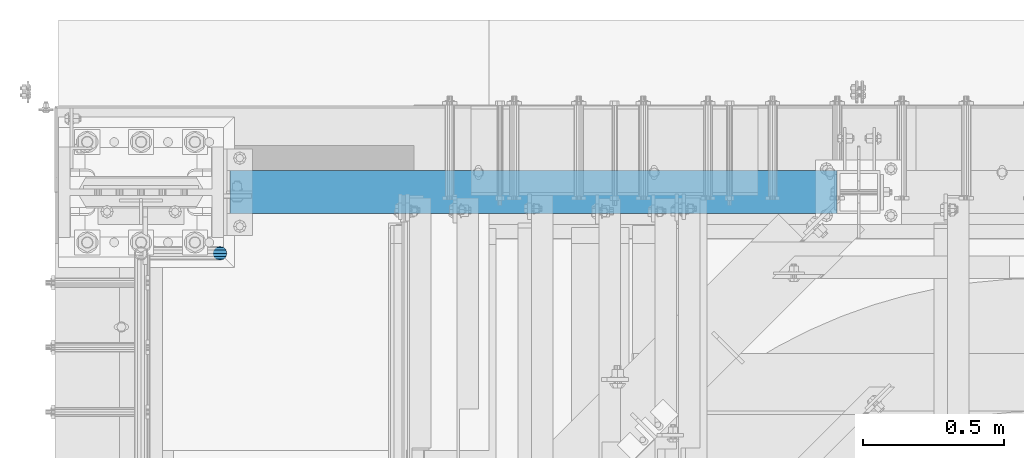
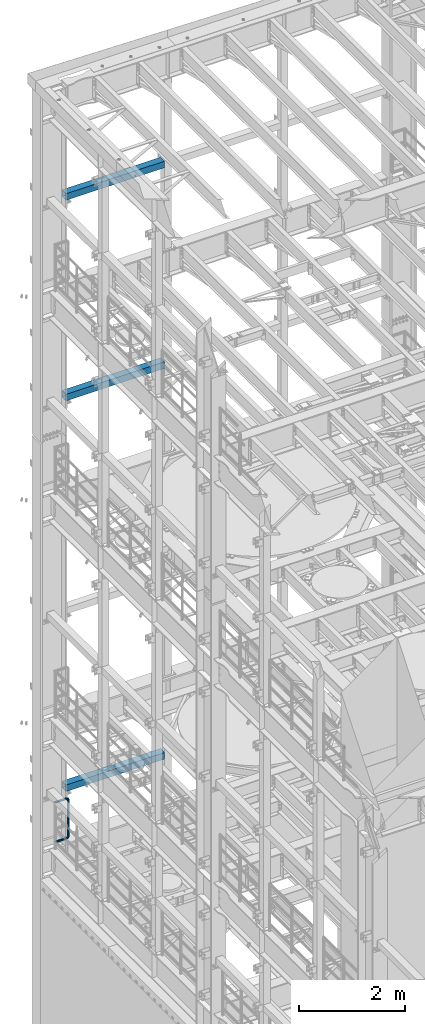
# One storey, part 1057 of 1876: 4 beams, 4 elements without a shape of their own.
"""IFC2X3 building model written with IfcOpenShell, lengths in millimetres."""

from ifc_helpers import new_model, si_unit, frame, origin_with_axes, place, context, subcontext, project, spatial, faceted_brep, material, type_object, element, aggregate, save


model = new_model("IFC2X3")

# Units and contexts
model_context = context("Model", 3, precision=1e-05, world=origin_with_axes())
body_context = subcontext(model_context, "Body", "Model", "MODEL_VIEW")
ifc_project = project(units=[si_unit("LENGTHUNIT", "METRE", prefix="MILLI"), si_unit("AREAUNIT", "SQUARE_METRE"), si_unit("VOLUMEUNIT", "CUBIC_METRE"), si_unit("MASSUNIT", "GRAM", prefix="KILO"), si_unit("TIMEUNIT", "SECOND"), si_unit("PLANEANGLEUNIT", "RADIAN"), si_unit("SOLIDANGLEUNIT", "STERADIAN"), si_unit("THERMODYNAMICTEMPERATUREUNIT", "DEGREE_CELSIUS"), si_unit("LUMINOUSINTENSITYUNIT", "LUMEN")], contexts=[model_context])

# Site, building, storey
site_placement = place(None, origin_with_axes())
site = spatial("IfcSite", under=ifc_project, at=site_placement, CompositionType="ELEMENT")
building_placement = place(site_placement, origin_with_axes())
building = spatial("IfcBuilding", under=site, at=building_placement, Name="Undefined", CompositionType="ELEMENT")
storey_placement = place(building_placement, origin_with_axes())
storey = spatial("IfcBuildingStorey", under=building, at=storey_placement, Name="Undefined", CompositionType="ELEMENT", Elevation=0.0)

# Assembly, beam
assembly_1_placement = place(storey_placement, origin_with_axes())
assembly_1 = element("IfcElementAssembly", 1, at=assembly_1_placement, inside=storey, Name="RAIL", AssemblyPlace="NOTDEFINED", PredefinedType="RIGID_FRAME")
ifc_material_1 = material()
beam_type_1 = type_object("IfcBeamType", Name="PIPE1-1/2SCH40", PredefinedType="NOTDEFINED")
beam_1_placement = place(assembly_1_placement, frame((-3.18323145620525e-12, 13499.7063, 6207.125), z_axis=(0.0, 0.0, 1.0), x_axis=(1.0, 0.0, 0.0)))
beam_1 = element("IfcBeam", 2, at=beam_1_placement, type_object=beam_type_1, material=ifc_material_1, Name="RAIL", ObjectType="PIPE1-1/2SCH40", context=body_context, shape_type="Brep", body=[
    faceted_brep([(1.20714750983051e-12, 24.1299999999974, -914.399963378906), (12.0650000000014, 20.8971929933159, -926.464963378905), (12.0650000000014, 20.8971929933177, -902.334963378908), (12.0650000000014, -20.8971929933195, -902.334963378908), (12.0650000000014, -20.8971929933195, -926.464963378905), (1.52133659548828e-12, -24.130000000001, -914.399963378906), (20.8971929933199, -12.0650000000023, -893.502770385589), (20.8971929933199, -12.0650000000005, -898.533841947723), (15.2545715621378, -17.7076214311819, -904.176463378906), (12.5151929933181, -20.4470000000019, -914.399963378906), (15.2545715621376, -17.7076214311819, -924.623463378906), (20.8971929933199, -12.0650000000005, -930.26608481009), (20.8971929933199, -12.0650000000023, -935.297156372224), (24.1300000000014, -1.81898940354586e-12, -934.846963378906), (24.1300000000014, -1.81898940354586e-12, -938.529963378907), (21.3906214311813, -10.2235000000019, -932.107584810088), (21.3906214311823, 10.2234999999982, -932.107584810088), (20.8971929933199, 12.0650000000005, -930.266084810086), (20.8971929933199, 12.0649999999987, -935.297156372224), (15.2545715621413, 17.7076214311783, -924.623463378906), (12.5151929933216, 20.4469999999983, -914.399963378906), (15.2545715621411, 17.7076214311783, -904.176463378906), (20.8971929933199, 12.0650000000005, -898.533841947727), (20.8971929933199, 12.0649999999987, -893.502770385589), (21.3906214311822, 10.2234999999982, -896.692341947724), (24.1300000000014, 0.0, -893.952963378906), (24.1300000000014, 0.0, -890.269963378905), (21.3906214311814, -10.2235000000019, -896.692341947724), (241.299995422363, -20.8971929933177, 12.0649999999987), (241.299995422363, -24.1299999999992, 0.0), (253.073542436527, -24.1299999999992, -1.86474665447167), (256.801832473661, -20.8971929933177, 9.60975021462946), (241.299995422363, -12.0650000000005, 20.8971929933177), (259.531130206197, -12.0650000000005, 18.0096649141014), (241.299995422363, 0.0, 24.130000000001), (260.530122510796, 0.0, 21.084247083727), (241.299995422363, 12.0650000000005, 20.8971929933177), (259.531130206197, 12.0650000000005, 18.0096649141014), (241.299995422363, 20.8971929933177, 12.0649999999987), (256.801832473661, 20.8971929933177, 9.60975021462946), (241.299995422363, 24.1299999999992, 0.0), (253.073542436527, 24.1299999999992, -1.86474665447167), (241.299995422363, 20.8971929933177, -12.0649999999987), (249.345252399393, 20.8971929933177, -13.3392435235728), (241.299995422363, 12.0650000000005, -20.8971929933177), (246.615954666858, 12.0650000000005, -21.7391582230448), (241.299995422363, 0.0, -24.130000000001), (245.616962362259, 0.0, -24.8137403926739), (241.299995422363, -12.0650000000005, -20.8971929933177), (246.615954666858, -12.0650000000005, -21.7391582230448), (241.299995422363, -20.8971929933177, -12.0649999999987), (249.345252399393, -20.8971929933177, -13.3392435235728), (267.334993896485, 20.8971929933177, -38.0999984741211), (279.399993896485, 24.1299999999992, -38.0999984741211), (279.399993896484, 24.1299999999992, -876.299964904785), (267.334993896484, 20.8971929933177, -876.299964904785), (291.464993896486, 20.8971929933177, -38.0999984741211), (291.464993896484, 20.8971929933177, -876.299964904785), (300.297186889804, 12.0650000000005, -38.0999984741211), (300.297186889803, 12.0650000000005, -876.299964904785), (303.529993896486, 0.0, -38.0999984741211), (303.529993896484, 0.0, -876.299964904785), (300.297186889804, -12.0650000000005, -38.0999984741211), (300.297186889803, -12.0650000000005, -876.299964904785), (291.464993896486, -20.8971929933177, -38.0999984741211), (291.464993896484, -20.8971929933177, -876.299964904785), (279.399993896484, -24.1299999999992, -38.0999984741211), (279.399993896484, -24.1299999999992, -876.299964904785), (267.334993896485, -20.8971929933177, -38.0999984741211), (267.334993896484, -20.8971929933177, -876.299964904785), (258.502800903167, -12.0650000000005, -38.0999984741211), (258.502800903166, -12.0650000000005, -876.299964904785), (255.269993896485, 0.0, -38.0999984741211), (255.269993896484, 0.0, -876.299964904785), (258.502800903167, 12.0650000000005, -38.0999984741211), (258.502800903166, 12.0650000000005, -876.299964904785), (257.660835673438, 12.0650000000005, -881.615924149282), (254.586253503809, 0.0, -880.616931844681), (257.660835673438, -12.0650000000005, -881.615924149282), (266.06075037291, -20.8971929933177, -884.345221881817), (277.535247242011, -24.130000000001, -888.073511918952), (289.009744111112, -20.8971929933195, -891.801801956084), (297.409658810584, -12.0650000000005, -894.531099688622), (300.484240980214, 0.0, -895.53009199322), (297.409658810584, 12.0650000000005, -894.531099688622), (289.009744111112, 20.8971929933177, -891.801801956084), (277.535247242011, 24.1299999999992, -888.073511918952), (266.06075037291, 20.8971929933177, -884.345221881817), (241.299995422364, -1.81898940354586e-12, -938.529963378911), (241.299995422364, -12.0650000000005, -935.297156372228), (241.299995422364, -20.8971929933195, -926.464963378909), (241.299995422363, -24.130000000001, -914.399963378906), (241.299995422363, -20.8971929933195, -902.334963378908), (241.299995422363, -12.0650000000005, -893.502770385589), (241.299995422363, 0.0, -890.269963378909), (241.299995422364, 20.8971929933177, -926.464963378909), (241.299995422364, 12.0649999999987, -935.297156372228), (241.299995422364, 24.1299999999992, -914.39996337891), (241.299995422363, 20.8971929933177, -902.334963378908), (241.299995422363, 12.0649999999987, -893.502770385589), (260.530122510801, 0.0, -935.484210462637), (259.531130206202, 12.0649999999987, -932.409628293008), (259.531130206201, -12.0650000000005, -932.409628293008), (256.801832473666, -20.8971929933195, -924.009713593536), (253.07354243653, -24.130000000001, -912.535216724435), (249.345252399395, -20.8971929933195, -901.060719855333), (246.615954666859, -12.0650000000005, -892.660805155861), (245.61696236226, 0.0, -889.586222986232), (246.615954666859, 12.0649999999987, -892.660805155861), (249.345252399395, 20.8971929933177, -901.060719855333), (253.07354243653, 24.1299999999992, -912.535216724435), (256.801832473666, 20.8971929933177, -924.009713593536), (275.977674493594, 12.0649999999987, -924.029695422345), (270.786241706733, 20.8971929933177, -916.884301193139), (277.877870775644, 0.0, -926.645091230272), (275.977674493608, -12.0650000000005, -924.029695422334), (270.786241706733, -20.8971929933195, -916.884301193139), (263.694612637823, -24.130000000001, -907.123511156005), (256.602983568912, -20.8971929933195, -897.362721118872), (251.411550782037, -12.0650000000005, -890.21732688968), (249.511354500001, 0.0, -887.601931081743), (251.411550782037, 12.0650000000005, -890.21732688968), (256.602983568912, 20.8971929933177, -897.362721118872), (263.694612637823, 24.1299999999992, -907.123511156005), (281.884331710718, 20.8971929933177, -905.786211189152), (272.123541673585, 24.1299999999992, -898.694582120243), (289.029725939912, 12.0650000000005, -910.977643976028), (291.645121747852, 0.0, -912.877840258065), (289.029725939912, -12.0650000000005, -910.977643976028), (281.884331710718, -20.8971929933195, -905.786211189152), (272.123541673585, -24.130000000001, -898.694582120243), (262.362751636451, -20.8971929933195, -891.602953051333), (255.217357407258, -12.0650000000005, -886.411520264461), (252.601961599318, 0.0, -884.511323982424), (255.217357407258, 12.0650000000005, -886.411520264461), (262.362751636451, 20.8971929933177, -891.602953051333), (266.060750372911, 20.8971929933177, -30.0547414970897), (257.660835673439, 12.0650000000005, -32.7840392296275), (277.535247242011, 24.1299999999992, -26.3264514599541), (289.009744111112, 20.8971929933177, -22.5981614228222), (297.409658810584, 12.0650000000005, -19.8688636902843), (300.484240980213, 0.0, -18.8698713856866), (297.409658810584, -12.0650000000005, -19.8688636902843), (289.009744111112, -20.8971929933177, -22.5981614228222), (277.535247242011, -24.1299999999992, -26.3264514599541), (266.060750372911, -20.8971929933177, -30.0547414970897), (257.660835673439, -12.0650000000005, -32.7840392296275), (254.58625350381, 0.0, -33.7830315342253), (255.217357407257, 12.0650000000005, -27.9884431144455), (252.601961599318, 0.0, -29.8886393964822), (262.362751636451, 20.8971929933177, -22.7970103275729), (272.123541673583, 24.1299999999992, -15.7053812586601), (281.884331710716, 20.8971929933177, -8.61375218975081), (289.029725939909, 12.0650000000005, -3.42231940287456), (291.645121747848, 0.0, -1.52212312084157), (289.029725939909, -12.0650000000005, -3.42231940287456), (281.884331710716, -20.8971929933177, -8.61375218975081), (272.123541673583, -24.1299999999992, -15.7053812586601), (262.362751636451, -20.8971929933177, -22.7970103275729), (255.217357407257, -12.0650000000005, -27.9884431144455), (249.511354500002, 0.0, -26.7980322971671), (251.411550782037, -12.0650000000005, -24.1826364892258), (251.411550782037, 12.0650000000005, -24.1826364892258), (256.602983568912, 20.8971929933177, -17.037242260034), (263.694612637822, 24.1299999999992, -7.27645222290084), (270.786241706732, 20.8971929933177, 2.48433781423228), (275.977674493607, 12.0650000000005, 9.62973204342416), (277.877870775642, 0.0, 12.2451278513654), (275.977674493607, -12.0650000000005, 9.62973204342416), (270.786241706732, -20.8971929933177, 2.48433781423228), (263.694612637822, -24.1299999999992, -7.27645222290084), (256.602983568912, -20.8971929933177, -17.037242260034), (24.1299999999854, -24.1299999999992, 0.0), (20.8971929933039, -20.8971929933177, -12.0649999999987), (12.0649999999854, -12.0650000000005, -20.8971929933177), (20.8971929933249, -12.0650000000005, -20.8971929933177), (16.4810997545745, -16.4810997545883, -16.48109323873), (24.1300000000063, 0.0, -24.130000000001), (-1.45519152283669e-11, 0.0, -24.130000000001), (20.8971929933249, 12.0650000000005, -20.8971929933177), (-12.0650000000145, 12.0650000000005, -20.8971929933177), (-20.897192993333, 20.8971929933177, -12.0649999999987), (-12.0649999999986, 20.8971929933177, -12.0649999999987), (12.0650000000064, 20.8971929933177, -12.0649999999987), (-16.481093238746, 16.4810932387318, -16.4810997545865), (0.0, 24.1299999999992, 0.0), (-24.1300000000145, 24.1299999999992, 0.0), (-20.897192993333, 20.8971929933177, 12.0649999999987), (-12.0650000000145, 12.0650000000005, 20.8971929933177), (-1.45519152283669e-11, 0.0, 24.130000000001), (12.0649999999854, -12.0650000000005, 20.8971929933177), (20.8971929933039, -20.8971929933177, 12.0649999999987), (241.299995422363, -17.7076214311801, 10.2235000000001), (241.299995422363, -20.4470000000001, 0.0), (20.4469999999854, -20.4470000000001, 0.0), (17.7076214311658, -17.7076214311801, 10.2235000000001), (241.299995422363, 0.0, 20.4470000000001), (241.299995422363, -10.2235000000001, 17.7076214311819), (10.2234999999854, -10.2235000000001, 17.7076214311819), (-1.45519152283669e-11, 0.0, 20.4470000000001), (241.299995422363, 10.2235000000001, 17.7076214311819), (-10.2235000000145, 10.2235000000001, 17.7076214311819), (241.299995422363, 17.7076214311801, 10.2235000000001), (-17.7076214311949, 17.7076214311801, 10.2235000000001), (241.299995422363, 20.4470000000001, 0.0), (-20.4470000000145, 20.4470000000001, 0.0), (241.299995422363, 17.7076214311801, -10.2235000000001), (-17.7076214311949, 17.7076214311801, -10.2235000000001), (241.299995422363, 10.2235000000001, -17.7076214311819), (-10.2235000000145, 10.2235000000001, -17.7076214311819), (241.299995422363, 0.0, -20.4470000000001), (-1.45519152283669e-11, 0.0, -20.4470000000001), (241.299995422363, -10.2235000000001, -17.7076214311819), (10.2234999999854, -10.2235000000001, -17.7076214311819), (241.299995422363, -17.7076214311801, -10.2235000000001), (17.7076214311658, -17.7076214311801, -10.2235000000001), (258.545498388721, -10.2235000000001, 14.9762020957387), (256.23277767852, -17.7076214311801, 7.85837963987069), (253.073542436527, -20.4470000000001, -1.86474665447167), (249.914307194535, -17.7076214311801, -11.5878729488177), (247.601586484334, -10.2235000000001, -18.7056954046857), (246.755071952542, 0.0, -21.31099924316), (247.601586484334, 10.2235000000001, -18.7056954046857), (249.914307194535, 17.7076214311801, -11.5878729488177), (253.073542436527, 20.4470000000001, -1.86474665447167), (256.23277767852, 17.7076214311801, 7.85837963987069), (258.545498388721, 10.2235000000001, 14.9762020957387), (259.392012920513, 0.0, 17.5815059342131), (275.713057691449, 0.0, 9.26551826108334), (274.10289136825, -10.2235000000001, 7.04931444488102), (274.10289136825, 10.2235000000001, 7.04931444488102), (269.703835164635, 17.7076214311801, 0.994533019089431), (263.694612637822, 20.4470000000001, -7.27645222290084), (257.685390111009, 17.7076214311801, -15.5474374648911), (253.286333907394, 10.2235000000001, -21.6022188906827), (251.676167584195, 0.0, -23.818422706885), (253.286333907394, -10.2235000000001, -21.6022188906827), (257.685390111009, -17.7076214311801, -15.5474374648911), (263.694612637822, -20.4470000000001, -7.27645222290084), (269.703835164635, -17.7076214311801, 0.994533019089431), (286.449308341364, -10.2235000000001, -5.29710252823133), (280.394526915574, -17.7076214311801, -9.69615873184739), (288.665512157566, 0.0, -3.68693620503473), (286.449308341364, 10.2235000000001, -5.29710252823133), (280.394526915574, 17.7076214311801, -9.69615873184739), (272.123541673583, 20.4470000000001, -15.7053812586601), (263.852556431592, 17.7076214311801, -21.7146037854764), (257.797775005802, 10.2235000000001, -26.1136599890888), (255.581571189601, 0.0, -27.723826312289), (257.797775005802, -10.2235000000001, -26.1136599890888), (263.852556431592, -17.7076214311801, -21.7146037854764), (272.123541673583, -20.4470000000001, -15.7053812586601), (287.258373536355, -17.7076214311801, -23.1672162179639), (277.535247242011, -20.4470000000001, -26.3264514599541), (294.376195992223, -10.2235000000001, -20.8544955077632), (296.981499830698, 0.0, -20.00798097597), (294.376195992223, 10.2235000000001, -20.8544955077632), (287.258373536355, 17.7076214311801, -23.1672162179639), (277.535247242011, 20.4470000000001, -26.3264514599541), (267.812120947668, 17.7076214311801, -29.485686701948), (260.6942984918, 10.2235000000001, -31.7984074121487), (258.088994653325, 0.0, -32.6449219439419), (260.6942984918, -10.2235000000001, -31.7984074121487), (267.812120947668, -17.7076214311801, -29.485686701948), (279.399993896484, -20.4470000000001, -38.0999984741211), (269.176493896485, -17.7076214311801, -38.0999984741211), (289.623493896486, -17.7076214311801, -38.0999984741211), (297.107615327666, -10.2235000000001, -38.0999984741211), (299.846993896486, 0.0, -38.0999984741211), (297.107615327666, 10.2235000000001, -38.0999984741211), (289.623493896486, 17.7076214311801, -38.0999984741211), (279.399993896485, 20.4470000000001, -38.0999984741211), (269.176493896485, 17.7076214311801, -38.0999984741211), (261.692372465305, 10.2235000000001, -38.0999984741211), (258.952993896485, 0.0, -38.0999984741211), (261.692372465305, -10.2235000000001, -38.0999984741211), (269.176493896484, -17.7076214311801, -876.299964904785), (261.692372465304, -10.2235000000001, -876.299964904785), (258.952993896484, 0.0, -876.299964904785), (261.692372465304, 10.2235000000001, -876.299964904785), (269.176493896484, 17.7076214311801, -876.299964904785), (279.399993896484, 20.4470000000001, -876.299964904785), (289.623493896484, 17.7076214311801, -876.299964904785), (297.107615327665, 10.2235000000001, -876.299964904785), (299.846993896484, 0.0, -876.299964904785), (297.107615327665, -10.2235000000001, -876.299964904785), (289.623493896484, -17.7076214311801, -876.299964904785), (279.399993896484, -20.4470000000001, -876.299964904785), (277.535247242011, -20.4470000000001, -888.073511918952), (267.812120947667, -17.7076214311801, -884.914276676958), (260.694298491799, -10.2235000000001, -882.601555966758), (258.088994653324, 0.0, -881.755041434964), (260.694298491799, 10.2235000000001, -882.601555966758), (267.812120947668, 17.7076214311801, -884.914276676958), (277.535247242011, 20.4470000000001, -888.073511918952), (287.258373536355, 17.7076214311801, -891.232747160942), (294.376195992223, 10.2235000000001, -893.545467871143), (296.981499830699, 0.0, -894.391982402936), (294.376195992223, -10.2235000000001, -893.545467871143), (287.258373536355, -17.7076214311801, -891.232747160942), (280.394526915577, -17.7076214311801, -904.703804647055), (272.123541673585, -20.4470000000001, -898.694582120243), (286.449308341367, -10.2235000000001, -909.102860850671), (288.665512157569, 0.0, -910.713027173868), (286.449308341367, 10.2235000000001, -909.102860850671), (280.394526915577, 17.7076214311801, -904.703804647055), (272.123541673585, 20.4470000000001, -898.694582120243), (263.852556431593, 17.7076214311801, -892.68535959343), (257.797775005802, 10.2235000000001, -888.286303389817), (255.581571189601, 0.0, -886.676137066617), (257.797775005802, -10.2235000000001, -888.286303389817), (263.852556431593, -17.7076214311801, -892.68535959343), (263.694612637823, -20.4470000000001, -907.123511156005), (257.685390111009, -17.7076214311801, -898.852525914015), (269.703835164636, -17.7076214311801, -915.394496397999), (274.102891368238, -10.2235000000001, -921.449277823798), (275.71305769145, 0.0, -923.66548163999), (274.102891368251, 10.2235000000001, -921.449277823787), (269.703835164636, 17.7076214311801, -915.394496397999), (263.694612637823, 20.4470000000001, -907.123511156005), (257.685390111009, 17.7076214311801, -898.852525914015), (253.286333907394, 10.2235000000001, -892.797744488227), (251.676167584195, 0.0, -890.581540672025), (253.286333907394, -10.2235000000001, -892.797744488227), (249.914307194537, -17.7076214311801, -902.812090430092), (247.601586484335, -10.2235000000001, -895.694267974224), (253.07354243653, -20.4470000000001, -912.535216724435), (256.232777678524, -17.7076214311819, -922.258343018777), (258.545498388725, -10.2235000000001, -929.376165474645), (259.392012920517, 0.0, -931.981469313119), (258.545498388725, 10.2235000000001, -929.376165474645), (256.232777678524, 17.7076214311801, -922.258343018777), (253.07354243653, 20.4470000000001, -912.535216724435), (249.914307194537, 17.7076214311801, -902.812090430092), (247.601586484335, 10.2235000000001, -895.694267974224), (246.755071952543, 0.0, -893.088964135746), (241.299995422363, -10.2235000000001, -896.692341947728), (241.299995422363, 0.0, -893.95296337891), (241.299995422363, -17.7076214311819, -904.17646337891), (241.299995422363, -20.4470000000001, -914.399963378906), (241.299995422364, -17.7076214311819, -924.62346337891), (241.299995422364, -10.2235000000001, -932.107584810088), (241.299995422364, -1.81898940354586e-12, -934.84696337891), (241.299995422364, 10.2234999999982, -932.107584810088), (241.299995422364, 17.7076214311801, -924.62346337891), (241.299995422364, 20.4470000000001, -914.39996337891), (241.299995422363, 17.7076214311801, -904.17646337891), (241.299995422363, 10.2235000000001, -896.692341947728)], [[[0, 1, 2]], [[3, 4, 5]], [[6, 7, 8, 9, 10, 11, 12, 4, 3]], [[13, 14, 12, 11, 15]], [[16, 17, 18, 14, 13]], [[2, 1, 18, 17, 19, 20, 21, 22, 23]], [[23, 22, 24, 25, 26]], [[26, 25, 27, 7, 6]], [[28, 29, 30, 31]], [[32, 28, 31, 33]], [[34, 32, 33, 35]], [[36, 34, 35, 37]], [[38, 36, 37, 39]], [[40, 38, 39, 41]], [[42, 40, 41, 43]], [[44, 42, 43, 45]], [[46, 44, 45, 47]], [[48, 46, 47, 49]], [[50, 48, 49, 51]], [[52, 53, 54, 55]], [[53, 56, 57, 54]], [[56, 58, 59, 57]], [[58, 60, 61, 59]], [[60, 62, 63, 61]], [[62, 64, 65, 63]], [[64, 66, 67, 65]], [[66, 68, 69, 67]], [[68, 70, 71, 69]], [[70, 72, 73, 71]], [[72, 74, 75, 73]], [[73, 75, 76, 77]], [[71, 73, 77, 78]], [[69, 71, 78, 79]], [[67, 69, 79, 80]], [[65, 67, 80, 81]], [[63, 65, 81, 82]], [[61, 63, 82, 83]], [[59, 61, 83, 84]], [[57, 59, 84, 85]], [[54, 57, 85, 86]], [[55, 54, 86, 87]], [[88, 89, 12, 14]], [[89, 90, 4, 12]], [[90, 91, 5, 4]], [[91, 92, 3, 5]], [[92, 93, 6, 3]], [[93, 94, 26, 6]], [[95, 96, 18, 1]], [[97, 95, 1, 0]], [[98, 97, 0, 2]], [[99, 98, 2, 23]], [[94, 99, 23, 26]], [[96, 88, 14, 18]], [[100, 88, 96, 101]], [[102, 89, 88, 100]], [[103, 90, 89, 102]], [[104, 91, 90, 103]], [[105, 92, 91, 104]], [[106, 93, 92, 105]], [[107, 94, 93, 106]], [[108, 99, 94, 107]], [[109, 98, 99, 108]], [[110, 97, 98, 109]], [[111, 95, 97, 110]], [[101, 96, 95, 111]], [[112, 101, 111, 113]], [[114, 100, 101, 112]], [[115, 102, 100, 114]], [[116, 103, 102, 115]], [[117, 104, 103, 116]], [[118, 105, 104, 117]], [[119, 106, 105, 118]], [[120, 107, 106, 119]], [[121, 108, 107, 120]], [[122, 109, 108, 121]], [[123, 110, 109, 122]], [[113, 111, 110, 123]], [[124, 113, 123, 125]], [[126, 112, 113, 124]], [[127, 114, 112, 126]], [[128, 115, 114, 127]], [[129, 116, 115, 128]], [[130, 117, 116, 129]], [[131, 118, 117, 130]], [[132, 119, 118, 131]], [[133, 120, 119, 132]], [[134, 121, 120, 133]], [[135, 122, 121, 134]], [[125, 123, 122, 135]], [[86, 125, 135, 87]], [[85, 124, 125, 86]], [[84, 126, 124, 85]], [[83, 127, 126, 84]], [[82, 128, 127, 83]], [[81, 129, 128, 82]], [[80, 130, 129, 81]], [[79, 131, 130, 80]], [[78, 132, 131, 79]], [[77, 133, 132, 78]], [[76, 134, 133, 77]], [[87, 135, 134, 76]], [[75, 55, 87, 76]], [[74, 52, 55, 75]], [[136, 52, 74, 137]], [[138, 53, 52, 136]], [[139, 56, 53, 138]], [[140, 58, 56, 139]], [[141, 60, 58, 140]], [[142, 62, 60, 141]], [[143, 64, 62, 142]], [[144, 66, 64, 143]], [[145, 68, 66, 144]], [[146, 70, 68, 145]], [[147, 72, 70, 146]], [[137, 74, 72, 147]], [[148, 137, 147, 149]], [[150, 136, 137, 148]], [[151, 138, 136, 150]], [[152, 139, 138, 151]], [[153, 140, 139, 152]], [[154, 141, 140, 153]], [[155, 142, 141, 154]], [[156, 143, 142, 155]], [[157, 144, 143, 156]], [[158, 145, 144, 157]], [[159, 146, 145, 158]], [[149, 147, 146, 159]], [[160, 149, 159, 161]], [[162, 148, 149, 160]], [[163, 150, 148, 162]], [[164, 151, 150, 163]], [[165, 152, 151, 164]], [[166, 153, 152, 165]], [[167, 154, 153, 166]], [[168, 155, 154, 167]], [[169, 156, 155, 168]], [[170, 157, 156, 169]], [[171, 158, 157, 170]], [[161, 159, 158, 171]], [[49, 161, 171, 51]], [[47, 160, 161, 49]], [[45, 162, 160, 47]], [[43, 163, 162, 45]], [[41, 164, 163, 43]], [[39, 165, 164, 41]], [[37, 166, 165, 39]], [[35, 167, 166, 37]], [[33, 168, 167, 35]], [[31, 169, 168, 33]], [[30, 170, 169, 31]], [[51, 171, 170, 30]], [[29, 50, 51, 30]], [[50, 29, 172, 173]], [[174, 175, 48, 50, 173, 176]], [[177, 46, 48, 175, 174, 178]], [[179, 44, 46, 177, 178, 180]], [[181, 182, 183, 42, 44, 179, 180, 184]], [[185, 40, 42, 183, 182, 181, 186]], [[38, 40, 185, 186, 187]], [[36, 38, 187, 188]], [[34, 36, 188, 189]], [[32, 34, 189, 190]], [[28, 32, 190, 191]], [[29, 28, 191, 172]], [[192, 193, 194, 195]], [[196, 197, 198, 199]], [[200, 196, 199, 201]], [[202, 200, 201, 203]], [[204, 202, 203, 205]], [[206, 204, 205, 207]], [[208, 206, 207, 209]], [[210, 208, 209, 211]], [[212, 210, 211, 213]], [[214, 212, 213, 215]], [[193, 214, 215, 194]], [[190, 189, 188, 187, 186, 181, 184, 180, 178, 174, 176, 173, 172, 191], [213, 211, 209, 207, 205, 203, 201, 199, 198, 195, 194, 215]], [[197, 192, 195, 198]], [[192, 197, 216, 217]], [[193, 192, 217, 218]], [[214, 193, 218, 219]], [[212, 214, 219, 220]], [[210, 212, 220, 221]], [[208, 210, 221, 222]], [[206, 208, 222, 223]], [[204, 206, 223, 224]], [[202, 204, 224, 225]], [[200, 202, 225, 226]], [[196, 200, 226, 227]], [[197, 196, 227, 216]], [[227, 228, 229, 216]], [[226, 230, 228, 227]], [[225, 231, 230, 226]], [[224, 232, 231, 225]], [[223, 233, 232, 224]], [[222, 234, 233, 223]], [[221, 235, 234, 222]], [[220, 236, 235, 221]], [[219, 237, 236, 220]], [[218, 238, 237, 219]], [[217, 239, 238, 218]], [[216, 229, 239, 217]], [[229, 240, 241, 239]], [[228, 242, 240, 229]], [[230, 243, 242, 228]], [[231, 244, 243, 230]], [[232, 245, 244, 231]], [[233, 246, 245, 232]], [[234, 247, 246, 233]], [[235, 248, 247, 234]], [[236, 249, 248, 235]], [[237, 250, 249, 236]], [[238, 251, 250, 237]], [[239, 241, 251, 238]], [[241, 252, 253, 251]], [[240, 254, 252, 241]], [[242, 255, 254, 240]], [[243, 256, 255, 242]], [[244, 257, 256, 243]], [[245, 258, 257, 244]], [[246, 259, 258, 245]], [[247, 260, 259, 246]], [[248, 261, 260, 247]], [[249, 262, 261, 248]], [[250, 263, 262, 249]], [[251, 253, 263, 250]], [[253, 264, 265, 263]], [[252, 266, 264, 253]], [[254, 267, 266, 252]], [[255, 268, 267, 254]], [[256, 269, 268, 255]], [[257, 270, 269, 256]], [[258, 271, 270, 257]], [[259, 272, 271, 258]], [[260, 273, 272, 259]], [[261, 274, 273, 260]], [[262, 275, 274, 261]], [[263, 265, 275, 262]], [[275, 265, 276, 277]], [[274, 275, 277, 278]], [[273, 274, 278, 279]], [[272, 273, 279, 280]], [[271, 272, 280, 281]], [[270, 271, 281, 282]], [[269, 270, 282, 283]], [[268, 269, 283, 284]], [[267, 268, 284, 285]], [[266, 267, 285, 286]], [[264, 266, 286, 287]], [[265, 264, 287, 276]], [[276, 287, 288, 289]], [[277, 276, 289, 290]], [[278, 277, 290, 291]], [[279, 278, 291, 292]], [[280, 279, 292, 293]], [[281, 280, 293, 294]], [[282, 281, 294, 295]], [[283, 282, 295, 296]], [[284, 283, 296, 297]], [[285, 284, 297, 298]], [[286, 285, 298, 299]], [[287, 286, 299, 288]], [[299, 300, 301, 288]], [[298, 302, 300, 299]], [[297, 303, 302, 298]], [[296, 304, 303, 297]], [[295, 305, 304, 296]], [[294, 306, 305, 295]], [[293, 307, 306, 294]], [[292, 308, 307, 293]], [[291, 309, 308, 292]], [[290, 310, 309, 291]], [[289, 311, 310, 290]], [[288, 301, 311, 289]], [[301, 312, 313, 311]], [[300, 314, 312, 301]], [[302, 315, 314, 300]], [[303, 316, 315, 302]], [[304, 317, 316, 303]], [[305, 318, 317, 304]], [[306, 319, 318, 305]], [[307, 320, 319, 306]], [[308, 321, 320, 307]], [[309, 322, 321, 308]], [[310, 323, 322, 309]], [[311, 313, 323, 310]], [[313, 324, 325, 323]], [[312, 326, 324, 313]], [[314, 327, 326, 312]], [[315, 328, 327, 314]], [[316, 329, 328, 315]], [[317, 330, 329, 316]], [[318, 331, 330, 317]], [[319, 332, 331, 318]], [[320, 333, 332, 319]], [[321, 334, 333, 320]], [[322, 335, 334, 321]], [[323, 325, 335, 322]], [[325, 336, 337, 335]], [[324, 338, 336, 325]], [[326, 339, 338, 324]], [[327, 340, 339, 326]], [[328, 341, 340, 327]], [[329, 342, 341, 328]], [[330, 343, 342, 329]], [[331, 344, 343, 330]], [[332, 345, 344, 331]], [[333, 346, 345, 332]], [[334, 347, 346, 333]], [[335, 337, 347, 334]], [[347, 337, 25, 24]], [[21, 346, 347, 24, 22]], [[345, 346, 21, 20]], [[344, 345, 20, 19]], [[343, 344, 19, 17, 16]], [[342, 343, 16, 13]], [[341, 342, 13, 15]], [[10, 340, 341, 15, 11]], [[339, 340, 10, 9]], [[338, 339, 9, 8]], [[336, 338, 8, 7, 27]], [[337, 336, 27, 25]]]),
])
aggregate(assembly_1, [beam_1])

assembly_2_placement = place(storey_placement, origin_with_axes())
assembly_2 = element("IfcElementAssembly", 3, at=assembly_2_placement, inside=storey, Name="FRAME", AssemblyPlace="NOTDEFINED", PredefinedType="RIGID_FRAME")
ifc_material_2 = material()
beam_type_2 = type_object("IfcBeamType", Name="HSS6X6X3/8", PredefinedType="NOTDEFINED")
beam_2_placement = place(assembly_2_placement, frame((304.799999999999, 13716.0, 6330.95), z_axis=(0.0, 1.0, 0.0), x_axis=(1.0, 0.0, 0.0)))
beam_2 = element("IfcBeam", 4, at=beam_2_placement, type_object=beam_type_2, material=ifc_material_2, Name="BEAM", ObjectType="HSS6X6X3/8", context=body_context, shape_type="Brep", body=[
    faceted_brep([(9.52500000000168, 66.6749999999993, -66.6750000000002), (9.52500000000168, -66.6749999999993, -66.6750000000002), (2159.0, -66.6750000000002, -66.6749999999993), (2159.0, 66.6750000000002, -66.6749999999993), (9.52500000000168, -66.6749999999993, 66.6750000000002), (2159.0, -66.6750000000002, 66.6749999999993), (9.52500000000168, 66.6749999999993, 66.6750000000002), (2159.0, 66.6750000000002, 66.6749999999993), (9.52500000000168, 76.2000000000007, -76.1999999999998), (9.52500000000168, 76.2000000000007, 76.1999999999998), (2159.0, 76.1999999999998, 76.2000000000007), (2159.0, 76.1999999999998, -76.2000000000007), (9.52500000000168, -76.2000000000007, 76.1999999999998), (2159.0, -76.1999999999998, 76.2000000000007), (9.52500000000168, -76.2000000000007, -76.1999999999998), (2159.0, -76.1999999999998, -76.2000000000007)], [[[0, 1, 2, 3]], [[1, 4, 5, 2]], [[4, 6, 7, 5]], [[6, 0, 3, 7]], [[8, 9, 10, 11]], [[9, 12, 13, 10]], [[12, 14, 15, 13]], [[14, 8, 11, 15]], [[13, 15, 11, 10], [5, 7, 3, 2]], [[14, 12, 9, 8], [6, 4, 1, 0]]]),
])
aggregate(assembly_2, [beam_2])

assembly_3_placement = place(storey_placement, origin_with_axes())
assembly_3 = element("IfcElementAssembly", 5, at=assembly_3_placement, inside=storey, Name="FRAME", AssemblyPlace="NOTDEFINED", PredefinedType="RIGID_FRAME")
beam_3_placement = place(assembly_3_placement, frame((304.799999999999, 13716.0, 19958.05), z_axis=(0.0, 1.0, 0.0), x_axis=(1.0, 0.0, 0.0)))
beam_3 = element("IfcBeam", 6, at=beam_3_placement, type_object=beam_type_2, material=ifc_material_2, Name="BEAM", ObjectType="HSS6X6X3/8", context=body_context, shape_type="Brep", body=[
    faceted_brep([(9.52500000000168, 66.6749999999993, -66.6750000000002), (9.52500000000168, -66.6749999999993, -66.6750000000002), (2159.0, -66.6750000000002, -66.6749999999993), (2159.0, 66.6750000000002, -66.6749999999993), (9.52500000000168, -66.6749999999993, 66.6750000000002), (2159.0, -66.6750000000002, 66.6749999999993), (9.52500000000168, 66.6749999999993, 66.6750000000002), (2159.0, 66.6750000000002, 66.6749999999993), (9.52500000000168, 76.2000000000007, -76.1999999999998), (9.52500000000168, 76.2000000000007, 76.1999999999998), (2159.0, 76.1999999999998, 76.2000000000007), (2159.0, 76.1999999999998, -76.2000000000007), (9.52500000000168, -76.2000000000007, 76.1999999999998), (2159.0, -76.1999999999998, 76.2000000000007), (9.52500000000168, -76.2000000000007, -76.1999999999998), (2159.0, -76.1999999999998, -76.2000000000007)], [[[0, 1, 2, 3]], [[1, 4, 5, 2]], [[4, 6, 7, 5]], [[6, 0, 3, 7]], [[8, 9, 10, 11]], [[9, 12, 13, 10]], [[12, 14, 15, 13]], [[14, 8, 11, 15]], [[13, 15, 11, 10], [5, 7, 3, 2]], [[14, 12, 9, 8], [6, 4, 1, 0]]]),
])
aggregate(assembly_3, [beam_3])

assembly_4_placement = place(storey_placement, origin_with_axes())
assembly_4 = element("IfcElementAssembly", 7, at=assembly_4_placement, inside=storey, Name="FRAME", AssemblyPlace="NOTDEFINED", PredefinedType="RIGID_FRAME")
beam_4_placement = place(assembly_4_placement, frame((304.799999999999, 13716.0, 15335.25), z_axis=(0.0, 1.0, 0.0), x_axis=(1.0, 0.0, 0.0)))
beam_4 = element("IfcBeam", 8, at=beam_4_placement, type_object=beam_type_2, material=ifc_material_2, Name="BEAM", ObjectType="HSS6X6X3/8", context=body_context, shape_type="Brep", body=[
    faceted_brep([(9.52500000000168, 66.6749999999993, -66.6750000000002), (9.52500000000168, -66.6749999999993, -66.6750000000002), (2159.0, -66.6750000000002, -66.6749999999993), (2159.0, 66.6750000000002, -66.6749999999993), (9.52500000000168, -66.6749999999993, 66.6750000000002), (2159.0, -66.6750000000002, 66.6749999999993), (9.52500000000168, 66.6749999999993, 66.6750000000002), (2159.0, 66.6750000000002, 66.6749999999993), (9.52500000000168, 76.2000000000007, -76.1999999999998), (9.52500000000168, 76.2000000000007, 76.1999999999998), (2159.0, 76.1999999999998, 76.2000000000007), (2159.0, 76.1999999999998, -76.2000000000007), (9.52500000000168, -76.2000000000007, 76.1999999999998), (2159.0, -76.1999999999998, 76.2000000000007), (9.52500000000168, -76.2000000000007, -76.1999999999998), (2159.0, -76.1999999999998, -76.2000000000007)], [[[0, 1, 2, 3]], [[1, 4, 5, 2]], [[4, 6, 7, 5]], [[6, 0, 3, 7]], [[8, 9, 10, 11]], [[9, 12, 13, 10]], [[12, 14, 15, 13]], [[14, 8, 11, 15]], [[13, 15, 11, 10], [5, 7, 3, 2]], [[14, 12, 9, 8], [6, 4, 1, 0]]]),
])
aggregate(assembly_4, [beam_4])

save(model, "model.ifc")
